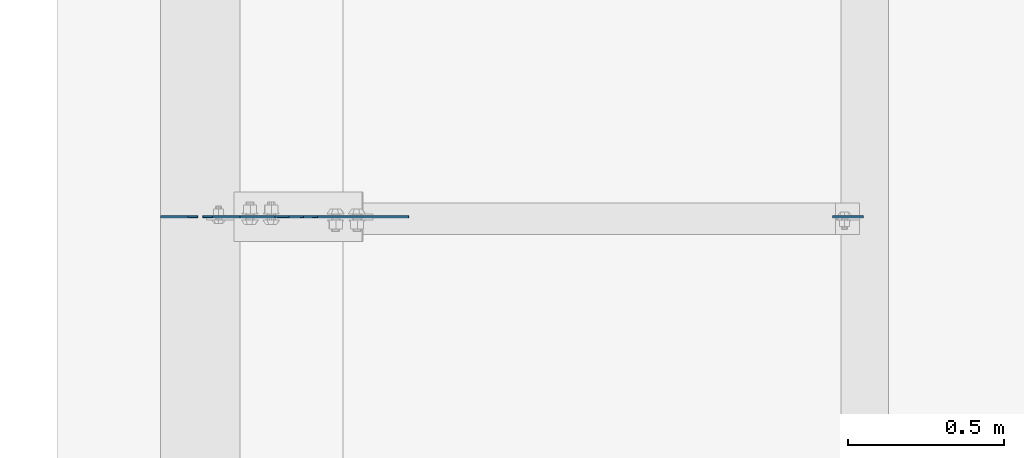
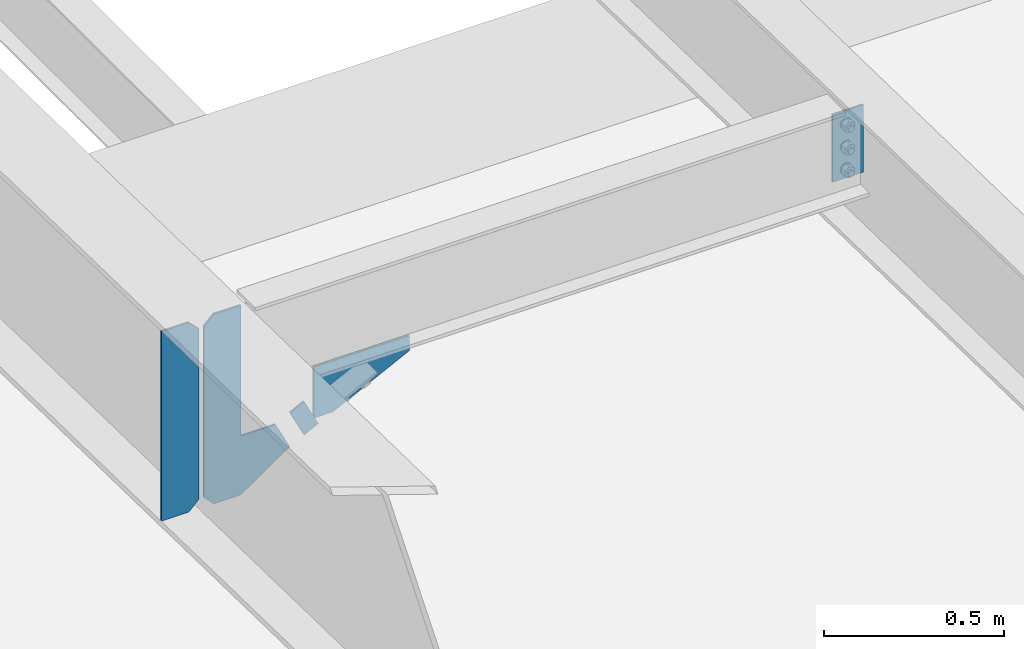
# One storey, part 1495 of 1763: 5 plates, 4 elements without a shape of their own.
"""IFC2X3 building model written with IfcOpenShell, lengths in millimetres."""

from ifc_helpers import new_model, si_unit, frame, origin_with_axes, place, context, subcontext, project, spatial, faceted_brep, material, type_object, element, aggregate, save


model = new_model("IFC2X3")

# Units and contexts
model_context = context("Model", 3, precision=1e-05, world=origin_with_axes())
body_context = subcontext(model_context, "Body", "Model", "MODEL_VIEW")
ifc_project = project(units=[si_unit("LENGTHUNIT", "METRE", prefix="MILLI"), si_unit("AREAUNIT", "SQUARE_METRE"), si_unit("VOLUMEUNIT", "CUBIC_METRE"), si_unit("MASSUNIT", "GRAM", prefix="KILO"), si_unit("TIMEUNIT", "SECOND"), si_unit("PLANEANGLEUNIT", "RADIAN"), si_unit("SOLIDANGLEUNIT", "STERADIAN"), si_unit("THERMODYNAMICTEMPERATUREUNIT", "DEGREE_CELSIUS"), si_unit("LUMINOUSINTENSITYUNIT", "LUMEN")], contexts=[model_context])

# Site, building, storey
site_placement = place(None, origin_with_axes())
site = spatial("IfcSite", under=ifc_project, at=site_placement, CompositionType="ELEMENT")
building_placement = place(site_placement, origin_with_axes())
building = spatial("IfcBuilding", under=site, at=building_placement, Name="Undefined", CompositionType="ELEMENT")
storey_placement = place(building_placement, origin_with_axes())
storey = spatial("IfcBuildingStorey", under=building, at=storey_placement, Name="Undefined", CompositionType="ELEMENT", Elevation=0.0)

# Assembly, plate
assembly_1_placement = place(storey_placement, origin_with_axes())
assembly_1 = element("IfcElementAssembly", 1, at=assembly_1_placement, inside=storey, Name="BEAM", AssemblyPlace="NOTDEFINED", PredefinedType="RIGID_FRAME")
ifc_material = material(Name="STEEL/A36")
plate_type_1 = type_object("IfcPlateType", PredefinedType="NOTDEFINED")
plate_1_placement = place(assembly_1_placement, frame((-87090.6652500603, 18802.3500000142, 11085.6696384137), z_axis=(0.894427191199916, 0.0, 0.447213595099958), x_axis=(0.447213595099924, 0.0, -0.894427191199933)))
plate_1 = element("IfcPlate", 2, at=plate_1_placement, type_object=plate_type_1, material=ifc_material, Name="PLATE", context=body_context, shape_type="Brep", body=[
    faceted_brep([(1.81898940354586e-12, -3.17500000000291, 0.0), (0.0, -3.17500000000291, 50.7999992370605), (0.0, 3.17500000000291, 50.7999992370605), (-1.81898940354586e-12, 3.17499999997381, 0.0), (101.599998474121, -3.17500000000291, 50.7999992370605), (101.599998474121, 3.17500000000291, 50.7999992370605), (101.599990844785, -3.17499999999927, -1.81898940354586e-11), (101.599990844785, 3.17499999999927, -1.81898940354586e-11)], [[[0, 1, 2, 3]], [[1, 4, 5, 2]], [[4, 6, 7, 5]], [[6, 0, 3, 7]], [[5, 7, 3, 2]], [[6, 4, 1, 0]]]),
])
aggregate(assembly_1, [plate_1])

assembly_2_placement = place(storey_placement, origin_with_axes())
assembly_2 = element("IfcElementAssembly", 3, at=assembly_2_placement, inside=storey, Name="BEAM", AssemblyPlace="NOTDEFINED", PredefinedType="RIGID_FRAME")
plate_type_2 = type_object("IfcPlateType", PredefinedType="NOTDEFINED")
plate_2_placement = place(assembly_2_placement, frame((-85253.0631665555, 18802.3499999985, 11486.9066248465), z_axis=(-1.0, 0.0, 0.0), x_axis=(0.0, 0.0, -1.0)))
plate_2 = element("IfcPlate", 4, at=plate_2_placement, type_object=plate_type_2, material=ifc_material, Name="PLATE", context=body_context, shape_type="Brep", body=[
    faceted_brep([(1.81898940354586e-12, -3.17500000000291, 0.0), (-2.52839527092874e-10, -3.17500000000001, 98.4250000002357), (4.17785486206412e-08, 3.17500000000001, 98.425000000243), (-1.81898940354586e-12, 3.17499999997381, 0.0), (228.600006103516, -3.17499999999927, 98.4250030517578), (228.600006103516, 3.17499999999927, 98.4250030517578), (228.600006103516, -3.17500000001019, -7.27595761418343e-12), (228.600006103516, 3.17499999999563, -7.27595761418343e-12)], [[[0, 1, 2, 3]], [[1, 4, 5, 2]], [[4, 6, 7, 5]], [[6, 0, 3, 7]], [[5, 7, 3, 2]], [[6, 4, 1, 0]]]),
])
aggregate(assembly_2, [plate_2])

assembly_3_placement = place(storey_placement, origin_with_axes())
assembly_3 = element("IfcElementAssembly", 5, at=assembly_3_placement, inside=storey, Name="BEAM", AssemblyPlace="NOTDEFINED", PredefinedType="RIGID_FRAME")
plate_type_3 = type_object("IfcPlateType", PredefinedType="NOTDEFINED")
plate_3_placement = place(assembly_3_placement, frame((-87367.1997736983, 18802.350000049, 10862.8077541186), z_axis=(0.0, 0.0, 1.0), x_axis=(1.0, 0.0, 0.0)))
plate_3 = element("IfcPlate", 6, at=plate_3_placement, type_object=plate_type_3, material=ifc_material, Name="PLATE", context=body_context, shape_type="Brep", body=[
    faceted_brep([(0.0, -3.17500000000291, 31.75), (0.0, -3.17499999999927, 611.195617675781), (0.0, 3.17499999999927, 611.195617675781), (0.0, 3.17500000000291, 31.75), (31.75, -3.17499999999927, 642.945617675781), (31.75, 3.17499999999927, 642.945617675781), (118.762496948242, -3.17499999999927, 642.945617675781), (118.762496948242, 3.17499999999927, 642.945617675781), (118.762496948242, -3.17499999999927, 199.747741699219), (118.762496948242, 3.17499999999927, 199.747741699219), (230.306228637695, -3.17499999999927, 199.747741699219), (230.306228637695, 3.17499999999927, 199.747741699219), (275.743133544922, -3.17499999999927, 108.873931884766), (275.743133544922, 3.17499999999927, 108.873931884766), (118.762496948242, -3.17499999999927, 0.0), (118.762496948242, 3.17499999999927, 0.0), (31.7499999999036, -3.17499999997381, 9.42916855706244e-11), (31.7499999998854, 3.17500000000291, 9.42916855706244e-11)], [[[0, 1, 2, 3]], [[1, 4, 5, 2]], [[4, 6, 7, 5]], [[6, 8, 9, 7]], [[8, 10, 11, 9]], [[10, 12, 13, 11]], [[12, 14, 15, 13]], [[14, 16, 17, 15]], [[16, 0, 3, 17]], [[5, 7, 9, 11, 13, 15, 17, 3, 2]], [[16, 14, 12, 10, 8, 6, 4, 1, 0]]]),
])

assembly_4_placement = place(storey_placement, origin_with_axes())
assembly_4 = element("IfcElementAssembly", 7, at=assembly_4_placement, inside=storey, Name="BEAM", AssemblyPlace="NOTDEFINED", PredefinedType="RIGID_FRAME")
plate_type_4 = type_object("IfcPlateType", PredefinedType="NOTDEFINED")
plate_4_placement = place(assembly_4_placement, frame((-87014.777246411, 18802.3500000004, 11213.8566193928), z_axis=(1.0, 0.0, 0.0), x_axis=(0.0, 0.0, -1.0)))
plate_4 = element("IfcPlate", 8, at=plate_4_placement, type_object=plate_type_4, material=ifc_material, Name="PLATE", context=body_context, shape_type="Brep", body=[
    faceted_brep([(1.81898940354586e-12, -3.17500000000291, 0.0), (0.0, -3.17499999999927, 306.070465087891), (0.0, 3.17499999999927, 306.070465087891), (-1.81898940354586e-12, 3.17499999997381, 0.0), (50.7999992370605, -3.17499999999927, 306.070465087891), (50.7999992370605, 3.17499999999927, 306.070465087891), (172.922760009766, -3.17499999999927, 61.8249359130859), (172.922760009766, 3.17499999999927, 61.8249359130859), (172.922760009766, -3.17499999999927, 0.0), (172.922760009766, 3.17499999999927, 0.0)], [[[0, 1, 2, 3]], [[1, 4, 5, 2]], [[4, 6, 7, 5]], [[6, 8, 9, 7]], [[8, 0, 3, 9]], [[5, 7, 9, 3, 2]], [[8, 6, 4, 1, 0]]]),
])
aggregate(assembly_4, [plate_4])

# Plate
plate_type_5 = type_object("IfcPlateType", PredefinedType="NOTDEFINED")
plate_5_placement = place(assembly_3_placement, frame((-87383.6747736984, 18802.350000049, 10862.8077541186), z_axis=(0.0, 0.0, 1.0), x_axis=(-1.0, 0.0, 0.0)))
plate_5 = element("IfcPlate", 9, at=plate_5_placement, type_object=plate_type_5, material=ifc_material, Name="PLATE", context=body_context, shape_type="Brep", body=[
    faceted_brep([(0.0, -3.17500000000291, 31.75), (0.0, -3.17499999999927, 611.195556640625), (0.0, 3.17499999999927, 611.195556640625), (0.0, 3.17500000000291, 31.75), (31.75, -3.17499999999927, 642.945556640625), (31.75, 3.17499999999927, 642.945556640625), (118.762496948242, -3.17499999999927, 642.945556640625), (118.762496948242, 3.17499999999927, 642.945556640625), (118.762496948242, -3.17499999999927, 0.0), (118.762496948242, 3.17499999999927, 0.0), (31.7499999999036, -3.17499999997381, 9.42916855706244e-11), (31.7499999998854, 3.17500000000291, 9.42916855706244e-11)], [[[0, 1, 2, 3]], [[1, 4, 5, 2]], [[4, 6, 7, 5]], [[6, 8, 9, 7]], [[8, 10, 11, 9]], [[10, 0, 3, 11]], [[5, 7, 9, 11, 3, 2]], [[10, 8, 6, 4, 1, 0]]]),
])

aggregate(assembly_3, [plate_5, plate_3])

save(model, "model.ifc")
